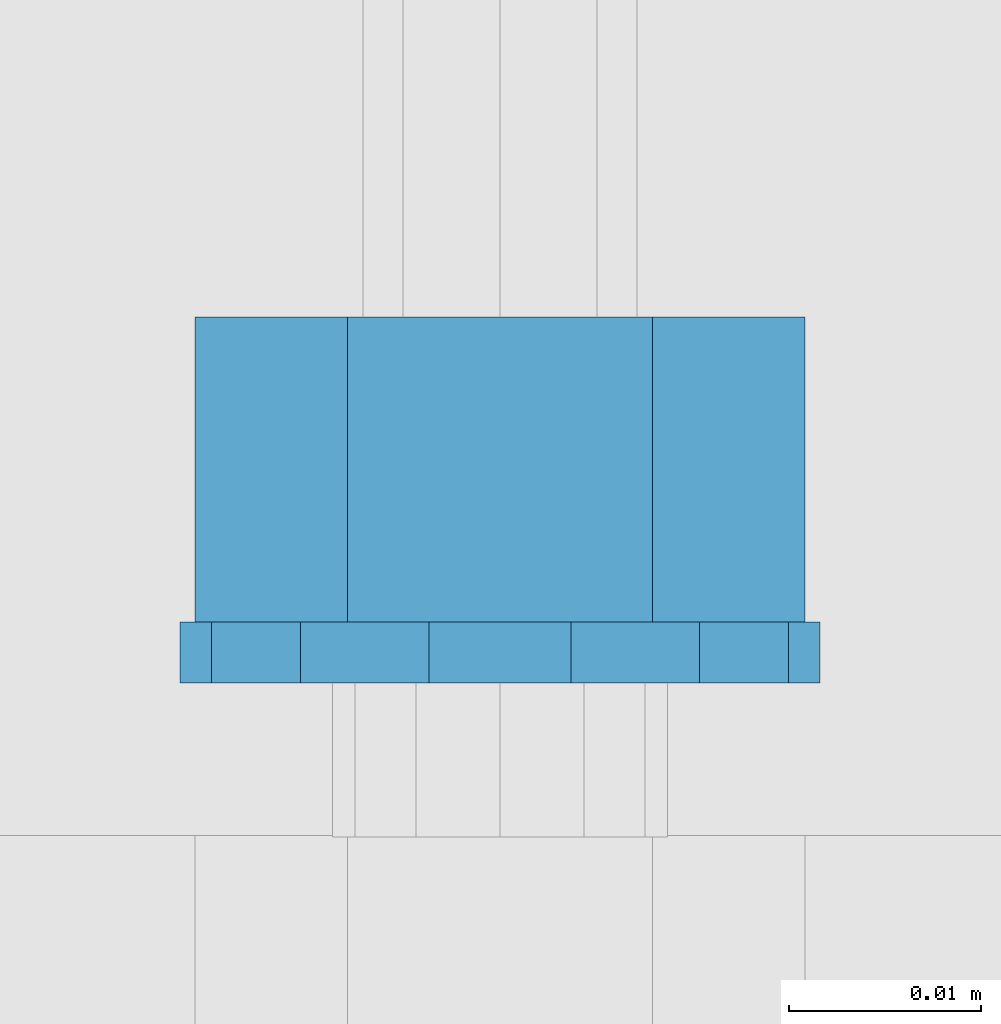
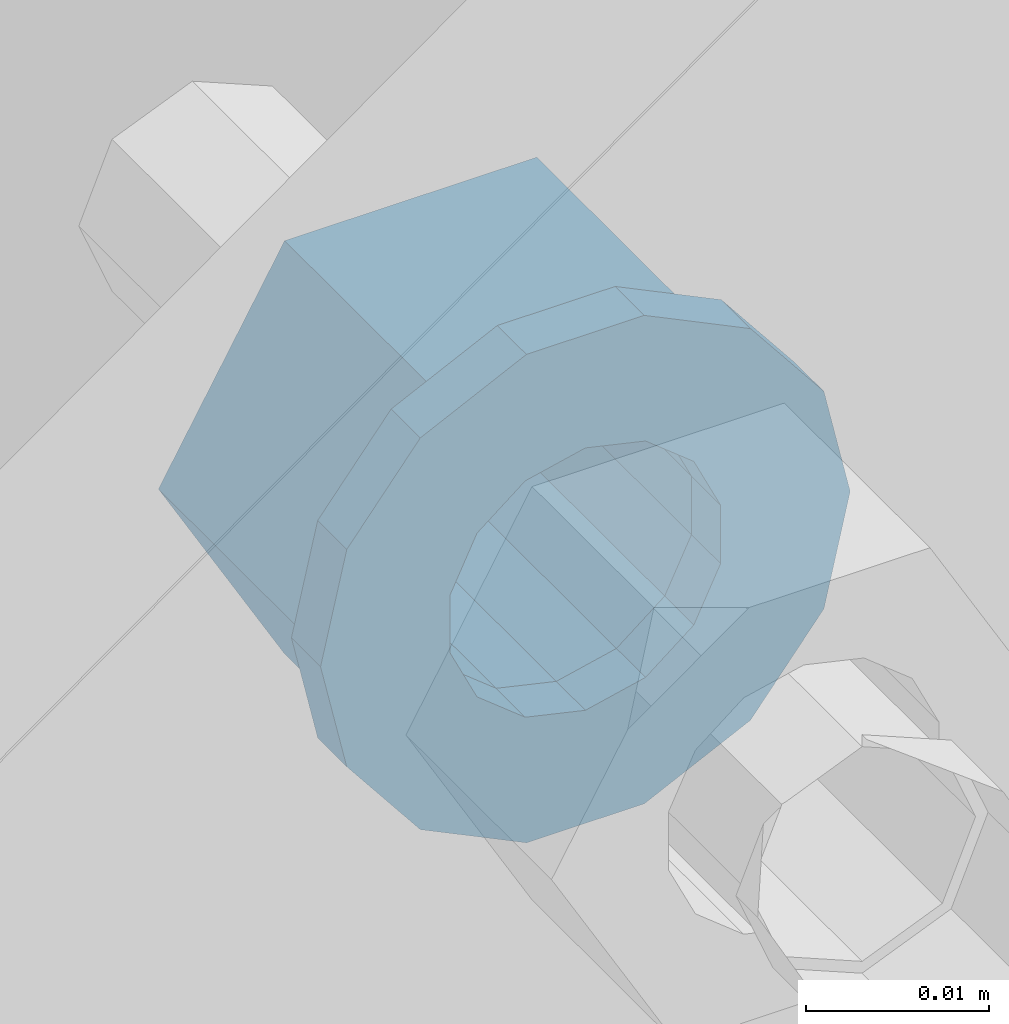
# One storey, part 537 of 975: 2 beams.
"""IFC2X3 building model written with IfcOpenShell, lengths in millimetres."""

from ifc_helpers import new_model, si_unit, frame, origin_with_axes, place, context, subcontext, project, spatial, faceted_brep, material, type_object, element, save


model = new_model("IFC2X3")

# Units and contexts
model_context = context("Model", 3, precision=1e-05, world=origin_with_axes())
body_context = subcontext(model_context, "Body", "Model", "MODEL_VIEW")
ifc_project = project(units=[si_unit("LENGTHUNIT", "METRE", prefix="MILLI"), si_unit("AREAUNIT", "SQUARE_METRE"), si_unit("VOLUMEUNIT", "CUBIC_METRE"), si_unit("MASSUNIT", "GRAM", prefix="KILO"), si_unit("TIMEUNIT", "SECOND"), si_unit("PLANEANGLEUNIT", "RADIAN"), si_unit("SOLIDANGLEUNIT", "STERADIAN"), si_unit("THERMODYNAMICTEMPERATUREUNIT", "DEGREE_CELSIUS"), si_unit("LUMINOUSINTENSITYUNIT", "LUMEN")], contexts=[model_context])

# Site, building, storey
site_placement = place(None, origin_with_axes())
site = spatial("IfcSite", under=ifc_project, at=site_placement, CompositionType="ELEMENT")
building_placement = place(site_placement, origin_with_axes())
building = spatial("IfcBuilding", under=site, at=building_placement, Name="Undefined", CompositionType="ELEMENT")
storey_placement = place(building_placement, origin_with_axes())
storey = spatial("IfcBuildingStorey", under=building, at=storey_placement, Name="Undefined", CompositionType="ELEMENT", Elevation=0.0)

# Beams
ifc_material = material(Name="STEEL/A36")
beam_type_1 = type_object("IfcBeamType", Name="5/8_HEAVY_HEX_NUT", PredefinedType="NOTDEFINED")
beam_1_placement = place(storey_placement, frame((1770.06247590906, 6008.68750005041, 3835.4), z_axis=(0.0, 0.0, -1.0), x_axis=(0.0, -1.0, 0.0)))
element("IfcBeam", 1, at=beam_1_placement, inside=storey, type_object=beam_type_1, material=ifc_material, Name="NUT", ObjectType="5/8_HEAVY_HEX_NUT", context=body_context, shape_type="Brep", body=[
    faceted_brep([(-1.09139364212751e-11, -15.8800001144436, -2.72848410531878e-12), (1.45519152283669e-11, -7.94000005722046, -13.7500000000036), (15.8750000000146, -7.94000005722137, -13.7500000000045), (15.8749999999891, -15.8800001144446, -2.72848410531878e-12), (2.91038304567337e-11, 7.94000005722319, -13.7500000000027), (15.8750000000291, 7.94000005722319, -13.7500000000027), (2.18278728425503e-11, 15.8800001144436, 9.09494701772928e-13), (15.8750000000218, 15.8800001144427, 9.09494701772928e-13), (-7.27595761418343e-12, 7.94000005722046, 13.7500000000027), (15.8749999999927, 7.94000005722046, 13.7500000000027), (-2.18278728425503e-11, -7.94000005722228, 13.7500000000009), (15.8749999999782, -7.94000005722319, 13.7500000000009), (-7.27595761418343e-12, 0.0, 8.72999954223724), (0.0, 3.78780484388062, 7.86545780435881), (15.875, 3.78780484387971, 7.86545780435881), (15.8749999999927, -9.09494701772928e-13, 8.72999954223724), (7.27595761418343e-12, 6.82538848405238, 5.44306568481716), (15.8750000000073, 6.82538848405238, 5.44306568481716), (1.09139364212751e-11, 8.51112022706275, 1.94260765157742), (15.8750000000109, 8.51112022706093, 1.94260765157651), (1.45519152283669e-11, 8.51112022706184, -1.94260765157651), (15.8750000000146, 8.51112022706184, -1.94260765157651), (2.18278728425503e-11, 6.8253884840542, -5.44306568481716), (15.8750000000218, 6.82538848405238, -5.44306568481716), (1.81898940354586e-11, 3.78780484388153, -7.86545780435881), (15.8750000000182, 3.78780484388062, -7.86545780435881), (1.81898940354586e-11, 9.09494701772928e-13, -8.72999954223997), (15.8750000000182, 9.09494701772928e-13, -8.72999954223997), (1.09139364212751e-11, -3.78780484387971, -7.86545780436063), (15.8750000000109, -3.78780484388062, -7.86545780436063), (3.63797880709171e-12, -6.82538848405238, -5.44306568481807), (15.8750000000036, -6.82538848405329, -5.44306568481807), (0.0, -8.51112022706184, -1.94260765157833), (15.875, -8.51112022706184, -1.94260765157833), (-7.27595761418343e-12, -8.51112022706184, 1.9426076515756), (15.8749999999927, -8.51112022706275, 1.9426076515756), (-1.09139364212751e-11, -6.82538848405329, 5.44306568481534), (15.8749999999927, -6.8253884840542, 5.44306568481534), (-7.27595761418343e-12, -3.78780484388062, 7.8654578043579), (15.8749999999927, -3.78780484388153, 7.8654578043579)], [[[0, 1, 2, 3]], [[1, 4, 5, 2]], [[4, 6, 7, 5]], [[6, 8, 9, 7]], [[8, 10, 11, 9]], [[10, 0, 3, 11]], [[12, 13, 14, 15]], [[13, 16, 17, 14]], [[16, 18, 19, 17]], [[18, 20, 21, 19]], [[20, 22, 23, 21]], [[22, 24, 25, 23]], [[24, 26, 27, 25]], [[26, 28, 29, 27]], [[28, 30, 31, 29]], [[30, 32, 33, 31]], [[32, 34, 35, 33]], [[34, 36, 37, 35]], [[36, 38, 39, 37]], [[38, 12, 15, 39]], [[5, 7, 9, 11, 3, 2], [17, 19, 21, 23, 25, 27, 29, 31, 33, 35, 37, 39, 15, 14]], [[10, 8, 6, 4, 1, 0], [38, 36, 34, 32, 30, 28, 26, 24, 22, 20, 18, 16, 13, 12]]]),
])
beam_type_2 = type_object("IfcBeamType", Name="5/8_WASHER", PredefinedType="NOTDEFINED")
beam_2_placement = place(storey_placement, frame((1770.06247590907, 5992.81250005041, 3835.4), z_axis=(0.0, 0.0, -1.0), x_axis=(0.0, -1.0, 0.0)))
element("IfcBeam", 2, at=beam_2_placement, inside=storey, type_object=beam_type_2, material=ifc_material, Name="WASHER", ObjectType="5/8_WASHER", context=body_context, shape_type="Brep", body=[
    faceted_brep([(1.09139364212751e-11, -16.670000076293, -2.72848410531878e-12), (2.18278728425503e-11, -15.0191510966704, -7.23284196419536), (3.1750000000211, -15.0191510966711, -7.23284196419627), (3.17500000001019, -16.6700000762937, -1.81898940354586e-12), (2.91038304567337e-11, -10.3935750445523, -13.0331308723944), (3.17500000002838, -10.3935750445526, -13.0331308723953), (2.91038304567337e-11, -3.70942398602756, -16.2520483704566), (3.17500000002838, -3.70942398602779, -16.2520483704566), (2.5465851649642e-11, 3.70942398602961, -16.2520483704557), (3.17500000002474, 3.70942398602961, -16.2520483704566), (1.45519152283669e-11, 10.3935750445542, -13.0331308723935), (3.17500000001382, 10.3935750445537, -13.0331308723944), (0.0, 15.0191510966717, -7.23284196419354), (3.17499999999927, 15.0191510966713, -7.23284196419354), (-7.27595761418343e-12, 16.6700000762933, 0.0), (3.174999999992, 16.6700000762928, -9.09494701772928e-13), (-1.81898940354586e-11, 15.0191510966706, 7.23284196419354), (3.17499999998108, 15.0191510966704, 7.23284196419354), (-2.5465851649642e-11, 10.3935750445519, 13.0331308723926), (3.17499999997381, 10.3935750445517, 13.0331308723926), (-2.5465851649642e-11, 3.70942398602733, 16.2520483704538), (3.17499999997381, 3.7094239860271, 16.2520483704529), (-2.18278728425503e-11, -3.70942398602983, 16.2520483704529), (3.17499999997744, -3.70942398603006, 16.2520483704538), (-1.09139364212751e-11, -10.3935750445542, 13.0331308723908), (3.17499999998836, -10.3935750445544, 13.0331308723908), (0.0, -15.0191510966717, 7.23284196419172), (3.17499999999927, -15.019151096672, 7.23284196419081), (-7.27595761418343e-12, 0.0, 8.72999954223724), (0.0, 3.78780484388062, 7.86545780435881), (3.17499999998472, 3.78780484387903, 7.86545780435699), (3.17499999998836, -9.09494701772928e-13, 8.72999954223542), (7.27595761418343e-12, 6.82538848405238, 5.44306568481716), (3.17499999998836, 6.82538848405102, 5.44306568481534), (1.09139364212751e-11, 8.51112022706275, 1.94260765157742), (3.174999999992, 8.51112022705979, 1.94260765157651), (1.45519152283669e-11, 8.51112022706184, -1.94260765157651), (3.17499999999563, 8.51112022706025, -1.94260765157742), (2.18278728425503e-11, 6.8253884840542, -5.44306568481716), (3.17500000000655, 6.8253884840517, -5.44306568481807), (1.81898940354586e-11, 3.78780484388153, -7.86545780435881), (3.17500000001019, 3.78780484388017, -7.86545780435972), (1.81898940354586e-11, 9.09494701772928e-13, -8.72999954223997), (3.17500000001382, 6.82121026329696e-13, -8.72999954223997), (1.09139364212751e-11, -3.78780484387971, -7.86545780436063), (3.17500000001382, -3.78780484387994, -7.86545780436063), (3.63797880709171e-12, -6.82538848405238, -5.44306568481807), (3.17500000001019, -6.82538848405147, -5.44306568481898), (0.0, -8.51112022706184, -1.94260765157833), (3.17500000001019, -8.5111202270607, -1.94260765157924), (-7.27595761418343e-12, -8.51112022706184, 1.9426076515756), (3.17500000000291, -8.51112022706093, 1.94260765157469), (-1.09139364212751e-11, -6.82538848405329, 5.44306568481534), (3.17499999999563, -6.82538848405238, 5.44306568481534), (-7.27595761418343e-12, -3.78780484388062, 7.8654578043579), (3.174999999992, -3.78780484388085, 7.86545780435699)], [[[0, 1, 2, 3]], [[1, 4, 5, 2]], [[4, 6, 7, 5]], [[6, 8, 9, 7]], [[8, 10, 11, 9]], [[10, 12, 13, 11]], [[12, 14, 15, 13]], [[14, 16, 17, 15]], [[16, 18, 19, 17]], [[18, 20, 21, 19]], [[20, 22, 23, 21]], [[22, 24, 25, 23]], [[24, 26, 27, 25]], [[26, 0, 3, 27]], [[28, 29, 30, 31]], [[29, 32, 33, 30]], [[32, 34, 35, 33]], [[34, 36, 37, 35]], [[36, 38, 39, 37]], [[38, 40, 41, 39]], [[40, 42, 43, 41]], [[42, 44, 45, 43]], [[44, 46, 47, 45]], [[46, 48, 49, 47]], [[48, 50, 51, 49]], [[50, 52, 53, 51]], [[52, 54, 55, 53]], [[54, 28, 31, 55]], [[5, 7, 9, 11, 13, 15, 17, 19, 21, 23, 25, 27, 3, 2], [33, 35, 37, 39, 41, 43, 45, 47, 49, 51, 53, 55, 31, 30]], [[26, 24, 22, 20, 18, 16, 14, 12, 10, 8, 6, 4, 1, 0], [54, 52, 50, 48, 46, 44, 42, 40, 38, 36, 34, 32, 29, 28]]]),
])

save(model, "model.ifc")
